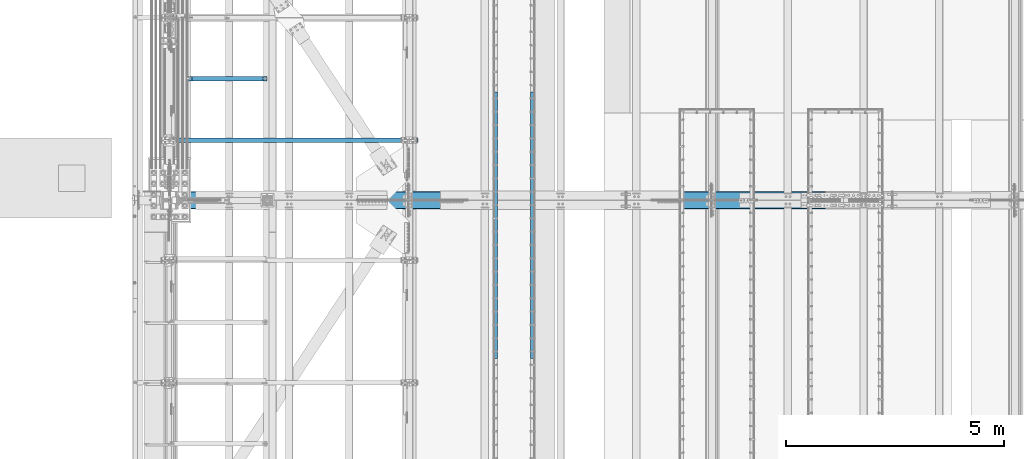
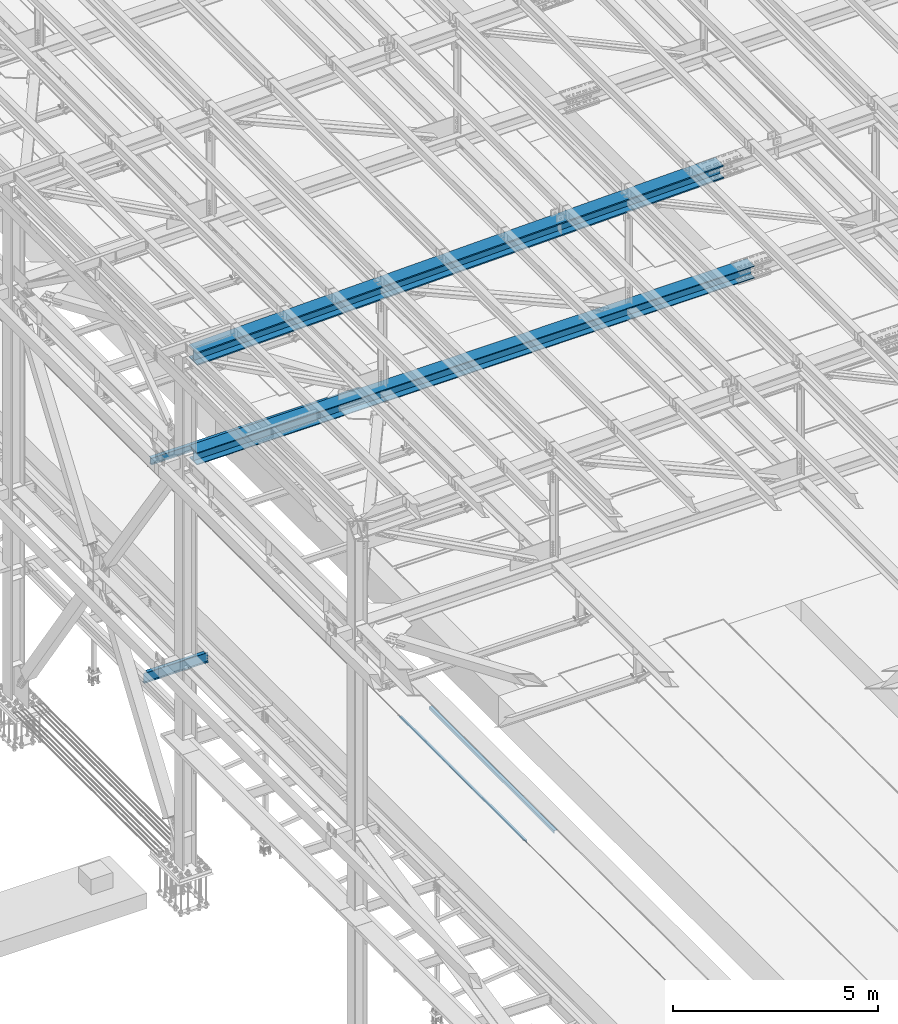
# One storey, part 1815 of 3843: 6 beams, 6 elements without a shape of their own.
"""IFC2X3 building model written with IfcOpenShell, lengths in millimetres."""

from ifc_helpers import new_model, si_unit, frame, origin_with_axes, place, context, subcontext, project, spatial, faceted_brep, material, type_object, element, aggregate, save


model = new_model("IFC2X3")

# Units and contexts
model_context = context("Model", 3, precision=1e-05, world=origin_with_axes())
body_context = subcontext(model_context, "Body", "Model", "MODEL_VIEW")
ifc_project = project(units=[si_unit("LENGTHUNIT", "METRE", prefix="MILLI"), si_unit("AREAUNIT", "SQUARE_METRE"), si_unit("VOLUMEUNIT", "CUBIC_METRE"), si_unit("MASSUNIT", "GRAM", prefix="KILO"), si_unit("TIMEUNIT", "SECOND"), si_unit("PLANEANGLEUNIT", "RADIAN"), si_unit("SOLIDANGLEUNIT", "STERADIAN"), si_unit("THERMODYNAMICTEMPERATUREUNIT", "DEGREE_CELSIUS"), si_unit("LUMINOUSINTENSITYUNIT", "LUMEN")], contexts=[model_context])

# Site, building, storey
site_placement = place(None, origin_with_axes())
site = spatial("IfcSite", under=ifc_project, at=site_placement, CompositionType="ELEMENT")
building_placement = place(site_placement, origin_with_axes())
building = spatial("IfcBuilding", under=site, at=building_placement, Name="Undefined", CompositionType="ELEMENT")
storey_placement = place(building_placement, origin_with_axes())
storey = spatial("IfcBuildingStorey", under=building, at=storey_placement, Name="Undefined", CompositionType="ELEMENT", Elevation=0.0)

# Assembly, beam
assembly_1_placement = place(storey_placement, origin_with_axes())
assembly_1 = element("IfcElementAssembly", 1, at=assembly_1_placement, inside=storey, Name="EMBED_ANGLE", AssemblyPlace="NOTDEFINED", PredefinedType="RIGID_FRAME")
ifc_material_1 = material(Name="STEEL/A36")
beam_type_1 = type_object("IfcBeamType", Name="L3-1/2X3-1/2X5/16", PredefinedType="NOTDEFINED")
beam_1_placement = place(assembly_1_placement, frame((44887.896, 53038.375, 30419.675), z_axis=(0.0, 0.0, -1.0), x_axis=(0.0, -1.0, 0.0)))
beam_1 = element("IfcBeam", 2, at=beam_1_placement, type_object=beam_type_1, material=ifc_material_1, Name="EMBED_ANGLE", ObjectType="L3-1/2X3-1/2X5/16", context=body_context, shape_type="Brep", body=[
    faceted_brep([(-3.63797880709171e-12, 44.4499999999971, -44.4500000000007), (-3.63797880709171e-12, 44.4499999999971, 44.4500000000007), (6096.0, 44.4499999999971, 44.4500000000007), (6096.0, 44.4499999999971, -44.4500000000007), (-3.63797880709171e-12, 36.5124999999971, 44.4500000000007), (6096.0, 36.5124999999971, 44.4500000000007), (-3.63797880709171e-12, 36.5124999999971, -36.5125000000007), (6096.0, 36.5124999999971, -36.5125000000007), (3.63797880709171e-12, -44.4499999999971, -36.5125000000007), (6096.0, -44.4499999999971, -36.5125000000007), (3.63797880709171e-12, -44.4499999999971, -44.4500000000007), (6096.0, -44.4499999999971, -44.4500000000007)], [[[0, 1, 2, 3]], [[1, 4, 5, 2]], [[4, 6, 7, 5]], [[6, 8, 9, 7]], [[8, 10, 11, 9]], [[10, 0, 3, 11]], [[5, 7, 9, 11, 3, 2]], [[10, 8, 6, 4, 1, 0]]]),
])
aggregate(assembly_1, [beam_1])

assembly_2_placement = place(storey_placement, origin_with_axes())
assembly_2 = element("IfcElementAssembly", 3, at=assembly_2_placement, inside=storey, Name="EMBED_ANGLE", AssemblyPlace="NOTDEFINED", PredefinedType="RIGID_FRAME")
beam_2_placement = place(assembly_2_placement, frame((44036.996, 46942.375, 30419.675), z_axis=(0.0, 0.0, -1.0), x_axis=(0.0, 1.0, 0.0)))
beam_2 = element("IfcBeam", 4, at=beam_2_placement, type_object=beam_type_1, material=ifc_material_1, Name="EMBED_ANGLE", ObjectType="L3-1/2X3-1/2X5/16", context=body_context, shape_type="Brep", body=[
    faceted_brep([(-3.63797880709171e-12, 44.4499999999971, -44.4500000000007), (-3.63797880709171e-12, 44.4499999999971, 44.4500000000007), (6096.0, 44.4499999999971, 44.4500000000007), (6096.0, 44.4499999999971, -44.4500000000007), (-3.63797880709171e-12, 36.5124999999971, 44.4500000000007), (6096.0, 36.5124999999971, 44.4500000000007), (-3.63797880709171e-12, 36.5124999999971, -36.5125000000007), (6096.0, 36.5124999999971, -36.5125000000007), (3.63797880709171e-12, -44.4499999999971, -36.5125000000007), (6096.0, -44.4499999999971, -36.5125000000007), (3.63797880709171e-12, -44.4499999999971, -44.4500000000007), (6096.0, -44.4499999999971, -44.4500000000007)], [[[0, 1, 2, 3]], [[1, 4, 5, 2]], [[4, 6, 7, 5]], [[6, 8, 9, 7]], [[8, 10, 11, 9]], [[10, 0, 3, 11]], [[5, 7, 9, 11, 3, 2]], [[10, 8, 6, 4, 1, 0]]]),
])
aggregate(assembly_2, [beam_2])

assembly_3_placement = place(storey_placement, origin_with_axes())
assembly_3 = element("IfcElementAssembly", 5, at=assembly_3_placement, inside=storey, Name="BEAM", AssemblyPlace="NOTDEFINED", PredefinedType="RIGID_FRAME")
ifc_material_2 = material(Name="STEEL/A992")
beam_type_2 = type_object("IfcBeamType", Name="W8X13", PredefinedType="NOTDEFINED")
beam_3_placement = place(assembly_3_placement, frame((36372.8, 51930.3, 41402.0), z_axis=(0.0, 0.0, 1.0), x_axis=(1.0, 0.0, 0.0)))
beam_3 = element("IfcBeam", 6, at=beam_3_placement, type_object=beam_type_2, material=ifc_material_2, Name="BEAM", ObjectType="W8X13", context=body_context, shape_type="Brep", body=[
    faceted_brep([(0.0, 50.7999999999993, -101.599999999999), (0.0, 50.7999999999993, -95.25), (5892.8, 50.7999999999993, -95.25), (5892.8, 50.7999999999993, -101.599999999999), (0.0, 3.17499999999927, -95.25), (5892.8, 3.17499999999927, -95.25), (-2.44140610448085e-05, 3.17500000000291, 95.2499999999927), (5892.8, 3.17499999999927, 95.25), (0.0, 50.7999999999993, 95.25), (5892.8, 50.7999999999993, 95.25), (0.0, 50.7999999999993, 101.599999999999), (5892.8, 50.7999999999993, 101.599999999999), (0.0, -50.7999999999993, 101.599999999999), (5892.8, -50.7999999999993, 101.599999999999), (0.0, -50.7999999999993, 95.25), (5892.8, -50.7999999999993, 95.25), (0.0, -3.17499999999927, 95.25), (5892.8, -3.17499999999927, 95.25), (0.0, -3.17499999999927, -95.25), (5892.8, -3.17499999999927, -95.25), (0.0, -50.7999999999993, -95.25), (5892.8, -50.7999999999993, -95.25), (0.0, -50.7999999999993, -101.599999999999), (5892.8, -50.7999999999993, -101.599999999999)], [[[0, 1, 2, 3]], [[1, 4, 5, 2]], [[4, 6, 7, 5]], [[6, 8, 9, 7]], [[8, 10, 11, 9]], [[10, 12, 13, 11]], [[12, 14, 15, 13]], [[14, 16, 17, 15]], [[16, 18, 19, 17]], [[18, 20, 21, 19]], [[20, 22, 23, 21]], [[22, 0, 3, 23]], [[5, 7, 9, 11, 13, 15, 17, 19, 21, 23, 3, 2]], [[22, 20, 18, 16, 14, 12, 10, 8, 6, 4, 1, 0]]]),
])
aggregate(assembly_3, [beam_3])

assembly_4_placement = place(storey_placement, origin_with_axes())
assembly_4 = element("IfcElementAssembly", 7, at=assembly_4_placement, inside=storey, Name="BEAM", AssemblyPlace="NOTDEFINED", PredefinedType="RIGID_FRAME")
beam_type_3 = type_object("IfcBeamType", Name="W14X193", PredefinedType="NOTDEFINED")
beam_4_placement = place(assembly_4_placement, frame((36581.3625036742, 50558.7, 45221.5979075414), z_axis=(-0.0258287689921344, 0.0, 0.999666381695589), x_axis=(0.999666381695589, 0.0, 0.0258287689921348)))
beam_4 = element("IfcBeam", 8, at=beam_4_placement, type_object=beam_type_3, material=ifc_material_2, Name="BEAM", ObjectType="W14X193", context=body_context, shape_type="Brep", body=[
    faceted_brep([(12012.8185823495, 11.1125000000029, 163.773914653771), (12012.8185823495, 200.025000000001, 163.773914653771), (13514.4492038619, 200.025000000001, 162.270411405174), (13514.4492038619, 11.1125000000029, 162.270411405174), (10511.1875921731, 11.1125000000029, 164.847845633012), (10511.1875921731, 200.025000000001, 164.847845633012), (9009.55635622083, 11.1125000000029, 165.492204254449), (9009.55635622083, 200.025000000001, 165.492204254449), (7507.9249973805, 11.1125000000029, 165.706990464962), (7507.9249973805, 200.025000000001, 165.706990464962), (6006.29363854018, 11.1125000000029, 165.492204248752), (6006.29363854018, 200.025000000001, 165.492204248752), (4504.66240258786, 11.1125000000029, 164.847845621625), (4504.66240258786, 200.025000000001, 164.847845621625), (3003.03141241152, 11.1125000000029, 163.77391463668), (3003.03141241152, 200.025000000001, 163.77391463668), (1501.40074602143, 11.1125000000029, 162.270411267753), (1501.40074602143, 200.024999999994, 162.270411267753), (211.581490863464, 11.1125000000029, 160.610003854294), (211.581490863464, 200.024999999994, 160.610003854294), (12012.5433754167, 200.025000000001, -156.90096725247), (12012.5433754167, 11.1125000000029, -156.90096725247), (13514.0822613197, 11.1125000000029, -158.404378651059), (13514.0822613197, 200.025000000001, -158.404378651059), (10511.0041208723, 200.025000000001, -155.827101880379), (10511.0041208723, 11.1125000000029, -155.827101880379), (9009.46462056696, 200.025000000001, -155.182782623247), (9009.46462056696, 11.1125000000029, -155.182782623247), (7507.92499738111, 200.025000000001, -154.968009534154), (7507.92499738111, 11.1125000000029, -154.968009534154), (6006.38537419526, 200.025000000001, -155.182782628937), (6006.38537419526, 11.1125000000029, -155.182782628937), (4504.8458738899, 200.025000000001, -155.827101891773), (4504.8458738899, 11.1125000000029, -155.827101891773), (3003.3066193455, 200.025000000001, -156.900967269568), (3003.3066193455, 11.1125000000029, -156.900967269568), (1501.76768855423, 200.024999999994, -158.404378788626), (1501.76768855423, 11.1125000000029, -158.404378788626), (203.295755423365, 200.025000000001, -160.07592494155), (203.295755423365, 11.1125000000029, -160.07592494155), (12012.5120399739, -200.025000000001, -193.413453806163), (12012.5120399739, 200.025000000001, -193.413453806163), (13514.0404807332, 200.025000000001, -194.916854746567), (13514.0404807332, -200.025000000001, -194.916854746567), (10510.9832305757, -200.025000000001, -192.339595904181), (10510.9832305757, 200.025000000001, -192.339595904181), (9009.45417541826, -200.025000000001, -191.695281129112), (9009.45417541826, 200.025000000001, -191.695281129112), (7507.92499738117, -200.025000000001, -191.480509534056), (7507.92499738117, 200.025000000001, -191.480509534056), (6006.39581934411, -200.025000000001, -191.695281134816), (6006.39581934411, 200.025000000001, -191.695281134816), (4504.86676418666, -200.025000000001, -192.339595915575), (4504.86676418666, 200.025000000001, -192.339595915575), (3003.33795478848, -200.025000000001, -193.413453823254), (3003.33795478848, 200.025000000001, -193.413453823254), (1501.80946913965, -200.024999999994, -194.916854884155), (1501.80946913965, 200.024999999994, -194.916854884155), (202.35233561309, -200.025000000001, -196.589669303205), (202.35233561309, 200.025000000001, -196.589669303205), (12012.5433754167, -11.1125000000029, -156.90096725247), (12012.5433754167, -200.025000000001, -156.90096725247), (13514.0822613197, -200.025000000001, -158.404378651059), (13514.0822613197, -11.1125000000029, -158.404378651059), (10511.0041208723, -11.1125000000029, -155.827101880379), (10511.0041208723, -200.025000000001, -155.827101880379), (9009.46462056696, -11.1125000000029, -155.182782623247), (9009.46462056696, -200.025000000001, -155.182782623247), (7507.92499738111, -11.1125000000029, -154.968009534154), (7507.92499738111, -200.025000000001, -154.968009534154), (6006.38537419526, -11.1125000000029, -155.182782628937), (6006.38537419526, -200.025000000001, -155.182782628937), (4504.8458738899, -11.1125000000029, -155.827101891773), (4504.8458738899, -200.025000000001, -155.827101891773), (3003.3066193455, -11.1125000000029, -156.900967269568), (3003.3066193455, -200.025000000001, -156.900967269568), (1501.76768855423, -11.1125000000029, -158.404378788626), (1501.76768855423, -200.024999999994, -158.404378788626), (203.295755423365, -11.1125000000029, -160.07592494155), (203.295755423365, -200.025000000001, -160.07592494155), (12012.8185823495, -200.025000000001, 163.773914653771), (12012.8185823495, -11.1125000000029, 163.773914653771), (13514.4492038619, -11.1125000000029, 162.270411405174), (13514.4492038619, -200.025000000001, 162.270411405174), (10511.1875921731, -200.025000000001, 164.847845633012), (10511.1875921731, -11.1125000000029, 164.847845633012), (9009.55635622083, -200.025000000001, 165.492204254449), (9009.55635622083, -11.1125000000029, 165.492204254449), (7507.9249973805, -200.025000000001, 165.706990464962), (7507.9249973805, -11.1125000000029, 165.706990464962), (6006.29363854018, -200.025000000001, 165.492204248752), (6006.29363854018, -11.1125000000029, 165.492204248752), (4504.66240258786, -200.025000000001, 164.847845621625), (4504.66240258786, -11.1125000000029, 164.847845621625), (3003.03141241152, -200.025000000001, 163.77391463668), (3003.03141241152, -11.1125000000029, 163.77391463668), (1501.40074602143, -200.024999999994, 162.270411267753), (1501.40074602143, -11.1125000000029, 162.270411267753), (211.581490863464, -200.024999999994, 160.610003854294), (211.581490863464, -11.1125000000029, 160.610003854294), (212.524853288371, -200.024999999994, 197.123748142047), (212.524853288371, 200.024999999994, 197.123748142047), (1501.358965436, -200.024999999994, 198.782887363275), (1501.358965436, 200.024999999994, 198.782887363275), (3003.00007696854, -200.025000000001, 200.286401190351), (3003.00007696854, 200.025000000001, 200.286401190351), (4504.64151229109, -200.025000000001, 201.36033964542), (4504.64151229109, 200.025000000001, 201.36033964542), (6006.28319339134, -200.025000000001, 202.004702754624), (6006.28319339134, 200.025000000001, 202.004702754624), (7507.92499738043, -200.025000000001, 202.219490464871), (7507.92499738043, 200.025000000001, 202.219490464871), (9009.56680136952, -200.025000000001, 202.004702760321), (9009.56680136952, 200.025000000001, 202.004702760321), (10511.2084824698, -200.025000000001, 201.360339656821), (10511.2084824698, 200.025000000001, 201.360339656821), (12012.8499177923, -200.025000000001, 200.28640120745), (12012.8499177923, 200.025000000001, 200.28640120745), (13514.4909844484, -200.025000000001, 198.782887500682), (13514.4909844484, 200.025000000001, 198.782887500682), (15009.7815648586, -200.025000000001, 196.857973121507), (15009.7815648586, 200.025000000001, 196.857973121507), (15009.7293546988, 200.025000000001, 160.345510452171), (15009.7293546988, 11.1125000000029, 160.345510452171), (15009.2708132949, 11.1125000000029, -160.329161687201), (15009.2708132949, 200.025000000001, -160.329161687201), (15009.2186031351, 200.025000000001, -196.841624356537), (15009.2186031351, -200.025000000001, -196.841624356537), (15009.2708132949, -200.025000000001, -160.329161687201), (15009.2708132949, -11.1125000000029, -160.329161687201), (15009.7293546988, -11.1125000000029, 160.345510452171), (15009.7293546988, -200.025000000001, 160.345510452171)], [[[0, 1, 2, 3]], [[4, 5, 1, 0]], [[6, 7, 5, 4]], [[8, 9, 7, 6]], [[10, 11, 9, 8]], [[12, 13, 11, 10]], [[14, 15, 13, 12]], [[16, 17, 15, 14]], [[17, 16, 18, 19]], [[20, 21, 22, 23]], [[24, 25, 21, 20]], [[26, 27, 25, 24]], [[28, 29, 27, 26]], [[30, 31, 29, 28]], [[32, 33, 31, 30]], [[34, 35, 33, 32]], [[36, 37, 35, 34]], [[37, 36, 38, 39]], [[40, 41, 42, 43]], [[44, 45, 41, 40]], [[46, 47, 45, 44]], [[48, 49, 47, 46]], [[50, 51, 49, 48]], [[52, 53, 51, 50]], [[54, 55, 53, 52]], [[56, 57, 55, 54]], [[57, 56, 58, 59]], [[60, 61, 62, 63]], [[64, 65, 61, 60]], [[66, 67, 65, 64]], [[68, 69, 67, 66]], [[70, 71, 69, 68]], [[72, 73, 71, 70]], [[74, 75, 73, 72]], [[76, 77, 75, 74]], [[77, 76, 78, 79]], [[80, 81, 82, 83]], [[84, 85, 81, 80]], [[86, 87, 85, 84]], [[88, 89, 87, 86]], [[90, 91, 89, 88]], [[92, 93, 91, 90]], [[94, 95, 93, 92]], [[96, 97, 95, 94]], [[97, 96, 98, 99]], [[19, 18, 39, 38, 59, 58, 79, 78, 99, 98, 100, 101]], [[102, 103, 101, 100]], [[103, 102, 104, 105]], [[105, 104, 106, 107]], [[107, 106, 108, 109]], [[109, 108, 110, 111]], [[111, 110, 112, 113]], [[113, 112, 114, 115]], [[115, 114, 116, 117]], [[117, 116, 118, 119]], [[119, 118, 120, 121]], [[2, 1, 5, 7, 9, 11, 13, 15, 17, 19, 101, 103, 105, 107, 109, 111, 113, 115, 117, 119, 121, 122]], [[3, 2, 122, 123]], [[22, 21, 25, 27, 29, 31, 33, 35, 37, 39, 18, 16, 14, 12, 10, 8, 6, 4, 0, 3, 123, 124]], [[23, 22, 124, 125]], [[42, 41, 45, 47, 49, 51, 53, 55, 57, 59, 38, 36, 34, 32, 30, 28, 26, 24, 20, 23, 125, 126]], [[43, 42, 126, 127]], [[62, 61, 65, 67, 69, 71, 73, 75, 77, 79, 58, 56, 54, 52, 50, 48, 46, 44, 40, 43, 127, 128]], [[63, 62, 128, 129]], [[82, 81, 85, 87, 89, 91, 93, 95, 97, 99, 78, 76, 74, 72, 70, 68, 66, 64, 60, 63, 129, 130]], [[83, 82, 130, 131]], [[118, 116, 114, 112, 110, 108, 106, 104, 102, 100, 98, 96, 94, 92, 90, 88, 86, 84, 80, 83, 131, 120]], [[130, 129, 128, 127, 126, 125, 124, 123, 122, 121, 120, 131]]]),
])
aggregate(assembly_4, [beam_4])

assembly_5_placement = place(storey_placement, origin_with_axes())
assembly_5 = element("IfcElementAssembly", 9, at=assembly_5_placement, inside=storey, Name="BEAM", AssemblyPlace="NOTDEFINED", PredefinedType="RIGID_FRAME")
beam_type_4 = type_object("IfcBeamType", Name="W14X120", PredefinedType="NOTDEFINED")
beam_5_placement = place(assembly_5_placement, frame((36576.0, 50558.7, 42246.5500000019), z_axis=(-0.00459547599882353, 0.0, 0.999989440744423), x_axis=(0.999989440744423, 0.0, 0.00459547599882549)))
beam_5 = element("IfcBeam", 10, at=beam_5_placement, type_object=beam_type_4, material=ifc_material_2, Name="BEAM", ObjectType="W14X120", context=body_context, shape_type="Brep", body=[
    faceted_brep([(9532.76983573709, 7.14375000000291, 166.10807235058), (9532.76983573709, 185.737500000003, 166.10807235058), (11121.605589387, 185.737500000003, 165.386727734025), (11121.605589387, 7.14375000000291, 165.386727734025), (7943.93393653315, 7.14375000000291, 166.348520565203), (7943.93393653315, 185.737500000003, 166.348520565203), (6355.09803732923, 7.14375000000291, 166.108072357412), (6355.09803732923, 185.737500000003, 166.108072357412), (4766.26228367927, 7.14375000000291, 165.386727747711), (4766.26228367927, 185.737500000003, 165.386727747711), (3177.42682113723, 7.14375000000291, 164.184486803148), (3177.42682113723, 185.737500000003, 164.184486803148), (1588.59179525702, 7.14375000000291, 162.501349633611), (1588.59179525702, 185.737500000003, 162.501349633611), (213.465468349867, 7.14375000000291, 160.628392326857), (213.465468349867, 185.737500000003, 160.628392326857), (12710.1498737679, 185.737500000003, -156.49038102031), (12710.1498737679, 7.14375000000291, -156.49038102031), (14298.8878403028, 7.14375000000291, -158.173415376579), (14298.8878403028, 185.737500000003, -158.173415376579), (11121.4114705979, 185.737500000003, -155.288213511856), (11121.4114705979, 7.14375000000291, -155.288213511856), (9532.67277633771, 185.737500000003, -154.566912961076), (9532.67277633771, 7.14375000000291, -154.566912961076), (7943.93393653246, 185.737500000003, -154.32647943504), (7943.93393653246, 7.14375000000291, -154.32647943504), (6355.19509672723, 185.737500000003, -154.566912954237), (6355.19509672723, 7.14375000000291, -154.566912954237), (4766.45640246706, 185.737500000003, -155.288213498177), (4766.45640246706, 7.14375000000291, -155.288213498177), (3177.71799929703, 185.737500000003, -156.4903809998), (3177.71799929703, 7.14375000000291, -156.4903809998), (1588.98003276216, 185.737500000003, -158.173415349222), (1588.98003276216, 7.14375000000291, -158.173415349222), (211.991687893009, 185.737500000003, -160.048908772165), (211.991687893009, 7.14375000000291, -160.048908772165), (12710.1282516272, -185.737500000003, -180.302871203705), (12710.1282516272, 185.737500000003, -180.302871203705), (14298.8590107849, 185.737500000003, -181.985897924809), (14298.8590107849, -185.737500000003, -181.985897924809), (11121.3970558363, -185.737500000003, -179.100709148923), (11121.3970558363, 185.737500000003, -179.100709148923), (9532.66556895657, -185.737500000003, -178.379411870359), (9532.66556895657, 185.737500000003, -178.379411870359), (7943.93393653242, -185.737500000003, -178.138979435062), (7943.93393653242, 185.737500000003, -178.138979435062), (6355.20230410826, -185.737500000003, -178.37941186352), (6355.20230410826, 185.737500000003, -178.37941186352), (4766.47081722854, -185.737500000003, -179.100709135244), (4766.47081722854, 185.737500000003, -179.100709135244), (3177.73962143761, -185.737500000003, -180.302871183179), (3177.73962143761, 185.737500000003, -180.302871183179), (1589.00886227988, -185.737500000003, -181.985897897459), (1589.00886227988, 185.737500000003, -181.985897897459), (211.882248750175, -185.737500000003, -183.861579645854), (211.882248750175, 185.737500000003, -183.861579645854), (12710.1498737679, -7.14375000000291, -156.49038102031), (12710.1498737679, -185.737500000003, -156.49038102031), (14298.8878403028, -185.737500000003, -158.173415376579), (14298.8878403028, -7.14375000000291, -158.173415376579), (11121.4114705979, -7.14375000000291, -155.288213511856), (11121.4114705979, -185.737500000003, -155.288213511856), (9532.67277633771, -7.14375000000291, -154.566912961076), (9532.67277633771, -185.737500000003, -154.566912961076), (7943.93393653246, -7.14375000000291, -154.32647943504), (7943.93393653246, -185.737500000003, -154.32647943504), (6355.19509672723, -7.14375000000291, -154.566912954237), (6355.19509672723, -185.737500000003, -154.566912954237), (4766.45640246706, -7.14375000000291, -155.288213498177), (4766.45640246706, -185.737500000003, -155.288213498177), (3177.71799929703, -7.14375000000291, -156.4903809998), (3177.71799929703, -185.737500000003, -156.4903809998), (1588.98003276216, -7.14375000000291, -158.173415349222), (1588.98003276216, -185.737500000003, -158.173415349222), (211.991687893009, -7.14375000000291, -160.048908772165), (211.991687893009, -185.737500000003, -160.048908772165), (12710.4410519291, -185.737500000003, 164.184486782622), (12710.4410519291, -7.14375000000291, 164.184486782622), (14299.2760778093, -7.14375000000291, 162.50134960626), (14299.2760778093, -185.737500000003, 162.50134960626), (11121.605589387, -185.737500000003, 165.386727734025), (11121.605589387, -7.14375000000291, 165.386727734025), (9532.76983573709, -185.737500000003, 166.10807235058), (9532.76983573709, -7.14375000000291, 166.10807235058), (7943.93393653315, -185.737500000003, 166.348520565203), (7943.93393653315, -7.14375000000291, 166.348520565203), (6355.09803732923, -185.737500000003, 166.108072357412), (6355.09803732923, -7.14375000000291, 166.108072357412), (4766.26228367927, -185.737500000003, 165.386727747711), (4766.26228367927, -7.14375000000291, 165.386727747711), (3177.42682113723, -185.737500000003, 164.184486803148), (3177.42682113723, -7.14375000000291, 164.184486803148), (1588.59179525702, -185.737500000003, 162.501349633611), (1588.59179525702, -7.14375000000291, 162.501349633611), (213.465468349867, -185.737500000003, 160.628392326857), (213.465468349867, -7.14375000000291, 160.628392326857), (213.574907492701, -185.737500000003, 184.441063200546), (213.574907492701, 185.737500000003, 184.441063200546), (1588.56296573931, -185.737500000003, 186.313832181841), (1588.56296573931, 185.737500000003, 186.313832181841), (3177.40519899665, -185.737500000003, 187.996976986527), (3177.40519899665, 185.737500000003, 187.996976986527), (4766.2478689178, -185.737500000003, 189.199223384785), (4766.2478689178, 185.737500000003, 189.199223384785), (6355.09082994819, -185.737500000003, 189.920571266695), (6355.09082994819, 185.737500000003, 189.920571266695), (7943.93393653321, -185.737500000003, 190.161020565218), (7943.93393653321, 185.737500000003, 190.161020565218), (9532.77704311822, -185.737500000003, 189.920571259856), (9532.77704311822, 185.737500000003, 189.920571259856), (11121.6200041486, -185.737500000003, 189.199223371106), (11121.6200041486, 185.737500000003, 189.199223371106), (12710.4626740698, -185.737500000003, 187.996976966009), (12710.4626740698, 185.737500000003, 187.996976966009), (14299.3049073271, -185.737500000003, 186.313832154483), (14299.3049073271, 185.737500000003, 186.313832154483), (15881.7970971804, -185.737500000003, 184.158437220045), (15881.7970971804, 185.737500000003, 184.158437220045), (14299.2760778093, 185.737500000003, 162.50134960626), (12710.4410519291, 185.737500000003, 164.184486782622), (15881.7609855781, 185.737500000003, 160.345964590204), (12710.4410519291, 7.14375000000291, 164.184486782622), (14299.2760778093, 7.14375000000291, 162.50134960626), (15881.7609855781, 7.14375000000291, 160.345964590204), (15881.2746826676, 7.14375000000291, -160.328666825037), (15881.2746826676, 185.737500000003, -160.328666825037), (15881.2385710653, 185.737500000003, -184.141139454885), (15881.2385710653, -185.737500000003, -184.141139454885), (15881.2746826676, -185.737500000003, -160.328666825037), (15881.2746826676, -7.14375000000291, -160.328666825037), (15881.7609855781, -7.14375000000291, 160.345964590204), (15881.7609855781, -185.737500000003, 160.345964590204)], [[[0, 1, 2, 3]], [[4, 5, 1, 0]], [[6, 7, 5, 4]], [[8, 9, 7, 6]], [[10, 11, 9, 8]], [[12, 13, 11, 10]], [[13, 12, 14, 15]], [[16, 17, 18, 19]], [[20, 21, 17, 16]], [[22, 23, 21, 20]], [[24, 25, 23, 22]], [[26, 27, 25, 24]], [[28, 29, 27, 26]], [[30, 31, 29, 28]], [[32, 33, 31, 30]], [[33, 32, 34, 35]], [[36, 37, 38, 39]], [[40, 41, 37, 36]], [[42, 43, 41, 40]], [[44, 45, 43, 42]], [[46, 47, 45, 44]], [[48, 49, 47, 46]], [[50, 51, 49, 48]], [[52, 53, 51, 50]], [[53, 52, 54, 55]], [[56, 57, 58, 59]], [[60, 61, 57, 56]], [[62, 63, 61, 60]], [[64, 65, 63, 62]], [[66, 67, 65, 64]], [[68, 69, 67, 66]], [[70, 71, 69, 68]], [[72, 73, 71, 70]], [[73, 72, 74, 75]], [[76, 77, 78, 79]], [[80, 81, 77, 76]], [[82, 83, 81, 80]], [[84, 85, 83, 82]], [[86, 87, 85, 84]], [[88, 89, 87, 86]], [[90, 91, 89, 88]], [[92, 93, 91, 90]], [[93, 92, 94, 95]], [[15, 14, 35, 34, 55, 54, 75, 74, 95, 94, 96, 97]], [[98, 99, 97, 96]], [[99, 98, 100, 101]], [[101, 100, 102, 103]], [[103, 102, 104, 105]], [[105, 104, 106, 107]], [[107, 106, 108, 109]], [[109, 108, 110, 111]], [[111, 110, 112, 113]], [[113, 112, 114, 115]], [[115, 114, 116, 117]], [[118, 119, 2, 1, 5, 7, 9, 11, 13, 15, 97, 99, 101, 103, 105, 107, 109, 111, 113, 115, 117, 120]], [[3, 2, 119, 121]], [[18, 17, 21, 23, 25, 27, 29, 31, 33, 35, 14, 12, 10, 8, 6, 4, 0, 3, 121, 122, 123, 124]], [[19, 18, 124, 125]], [[38, 37, 41, 43, 45, 47, 49, 51, 53, 55, 34, 32, 30, 28, 26, 24, 22, 20, 16, 19, 125, 126]], [[39, 38, 126, 127]], [[58, 57, 61, 63, 65, 67, 69, 71, 73, 75, 54, 52, 50, 48, 46, 44, 42, 40, 36, 39, 127, 128]], [[59, 58, 128, 129]], [[78, 77, 81, 83, 85, 87, 89, 91, 93, 95, 74, 72, 70, 68, 66, 64, 62, 60, 56, 59, 129, 130]], [[79, 78, 130, 131]], [[114, 112, 110, 108, 106, 104, 102, 100, 98, 96, 94, 92, 90, 88, 86, 84, 82, 80, 76, 79, 131, 116]], [[130, 129, 128, 127, 126, 125, 124, 123, 120, 117, 116, 131]], [[122, 118, 120, 123]], [[121, 119, 118, 122]]]),
])
aggregate(assembly_5, [beam_5])

assembly_6_placement = place(storey_placement, origin_with_axes())
assembly_6 = element("IfcElementAssembly", 11, at=assembly_6_placement, inside=storey, Name="BEAM", AssemblyPlace="NOTDEFINED", PredefinedType="RIGID_FRAME")
beam_type_5 = type_object("IfcBeamType", Name="W12X14", PredefinedType="NOTDEFINED")
beam_6_placement = place(assembly_6_placement, frame((36982.4, 53344.167188, 33885.1875), z_axis=(0.0, 0.0, 1.0), x_axis=(1.0, 0.0, 0.0)))
beam_6 = element("IfcBeam", 12, at=beam_6_placement, type_object=beam_type_5, material=ifc_material_2, Name="BEAM", ObjectType="W12X14", context=body_context, shape_type="Brep", body=[
    faceted_brep([(92.8687501907334, -2.38125000000582, 125.412499999991), (92.8687501907334, 2.38125000000582, 125.412499999991), (16.6687499999971, 2.38125000000582, 125.412499999991), (16.6687499999971, -2.38125000000582, 125.412499999991), (97.7288297087798, -2.38125000000582, 126.379229922582), (97.7288297087798, 2.38125000000582, 126.379229922582), (101.849006176933, -2.38125000000582, 129.132243823056), (101.849006176933, 2.38125000000582, 129.132243823056), (104.602020077407, -2.38125000000582, 133.25242029121), (104.602020077407, 2.38125000000582, 133.25242029121), (105.568749999999, -2.38125000000582, 138.112499809256), (105.568749999999, 2.38125000000582, 138.112499809256), (105.568749999999, -50.8000000000029, 150.812499810811), (105.568749999999, 50.8000000000029, 150.8125), (105.568749999999, 50.8000000000029, 144.462500000001), (105.568749999999, 2.38125000000582, 144.462500000001), (105.568749999999, -2.38125000000582, 144.462500000001), (105.568749999999, -50.8000000000029, 144.462500000001), (16.6687499999971, -2.38125000000582, -144.462500000001), (16.6687499999971, -50.7999999999993, -144.462500000001), (1821.65625, -50.8000000000029, -144.462500000001), (1821.65625, -2.38125000000582, -144.462500000001), (16.6687499999971, -50.8000000000029, -150.8125), (1821.65625, -50.8000000000029, -150.8125), (16.6687499999971, 50.8000000000029, -150.8125), (1821.65625, 50.8000000000029, -150.8125), (16.6687499999971, 50.7999999999993, -144.462500000001), (1821.65625, 50.8000000000029, -144.462500000001), (16.6687499999971, 2.38125000000582, -144.462500000001), (1821.65625, 2.38125000000582, -144.462500000001), (1821.65625, 2.38125000000582, -117.887499999997), (1821.65625, 2.38125000000582, 112.712500000001), (1821.65625, 2.38125000000582, 125.412499999991), (1821.65625, -2.38125000000582, 125.412499999991), (1745.45624980926, 2.38125000000582, 125.412499999991), (1745.45624980926, -2.38125000000582, 125.412499999991), (1740.59617029122, 2.38125000000582, 126.379229922582), (1740.59617029122, -2.38125000000582, 126.379229922582), (1736.47599382306, 2.38125000000582, 129.132243823056), (1736.47599382306, -2.38125000000582, 129.132243823056), (1733.72297992259, 2.38125000000582, 133.25242029121), (1733.72297992259, -2.38125000000582, 133.25242029121), (1732.75625, 2.38125000000582, 138.112499809256), (1732.75625, -2.38125000000582, 138.112499809256), (1732.75625, -50.8000000000029, 150.8125), (1732.75625, -50.8000000000029, 144.462500000001), (1732.75625, -2.38125000000582, 144.462500000001), (1732.75625, 2.38125000000582, 144.462500000001), (1732.75625, 50.8000000000029, 144.462500000001), (1732.75625, 50.8000000000029, 150.8125), (16.6687499999971, 2.38125000000582, 112.712500000001), (16.6687499999971, 2.38125000000582, -117.887499999997)], [[[0, 1, 2, 3]], [[4, 5, 1, 0]], [[6, 7, 5, 4]], [[8, 9, 7, 6]], [[10, 11, 9, 8]], [[12, 13, 14, 15, 11, 10, 16, 17]], [[18, 19, 20, 21]], [[19, 22, 23, 20]], [[22, 24, 25, 23]], [[24, 26, 27, 25]], [[26, 28, 29, 27]], [[21, 20, 23, 25, 27, 29, 30, 31, 32, 33]], [[33, 32, 34, 35]], [[35, 34, 36, 37]], [[37, 36, 38, 39]], [[39, 38, 40, 41]], [[41, 40, 42, 43]], [[44, 45, 46, 43, 42, 47, 48, 49]], [[45, 44, 12, 17]], [[46, 45, 17, 16]], [[8, 6, 4, 0, 3, 18, 21, 33, 35, 37, 39, 41, 43, 46, 16, 10]], [[50, 51, 28, 26, 24, 22, 19, 18, 3, 2]], [[47, 42, 40, 38, 36, 34, 32, 31, 30, 29, 28, 51, 50, 2, 1, 5, 7, 9, 11, 15]], [[48, 47, 15, 14]], [[49, 48, 14, 13]], [[44, 49, 13, 12]]]),
])
aggregate(assembly_6, [beam_6])

save(model, "model.ifc")
